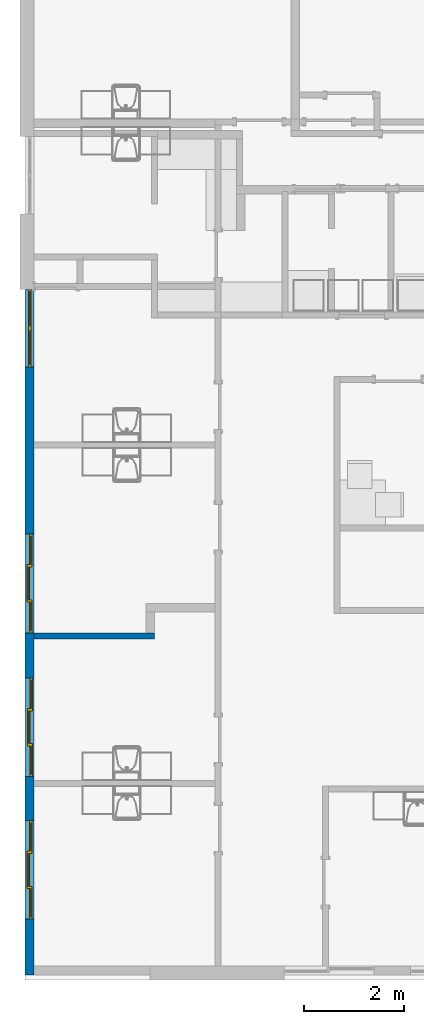
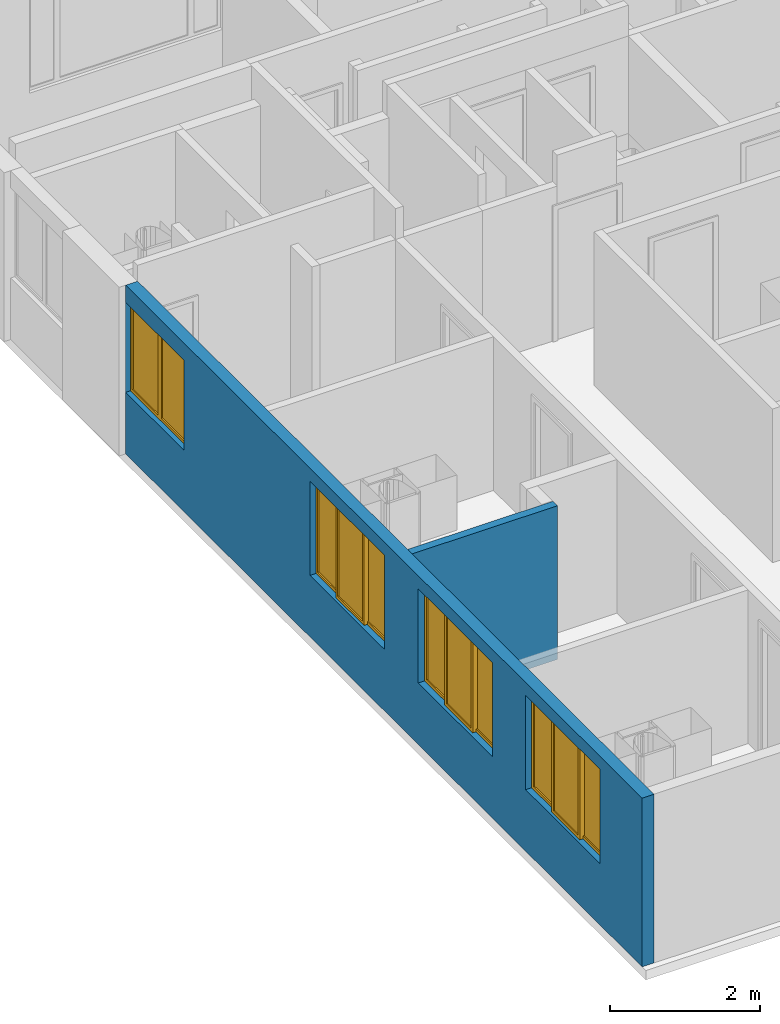
# One storey, part 3 of 64: 4 windows, 2 walls, 4 openings.
"""IFC4 building model written with IfcOpenShell, lengths in feet."""

from ifc_helpers import new_model, entity, si_unit, converted_unit, frame, origin_with_axes, origin_2d_with_axis, place, context, subcontext, project, spatial, line, indexed_curve, outline, extrude, polygons, source, transform, mapped, material, layer, layer_set, layer_usage, type_object, type_shapes, element, fill, save


model = new_model("IFC4")

# Units and contexts
model_context = context("Model", 3, precision=1e-05, world=origin_with_axes())
plan_context = context("Plan", 2, precision=1e-05, world=origin_2d_with_axis())
context_of_model_1 = context(None, 3, precision=1e-05, world=origin_with_axes())
context_of_model_2 = context(None, 3, precision=1e-05, world=origin_with_axes())
body_context = subcontext(model_context, "Body", "Model", "MODEL_VIEW")
ifc_project = project(units=[converted_unit("PLANEANGLEUNIT", "degree", entity("IfcReal", 0.0174532925199433), si_unit("PLANEANGLEUNIT", "RADIAN"), dimensions=[0, 0, 0, 0, 0, 0, 0]), converted_unit("AREAUNIT", "square foot", entity("IfcReal", 0.09290304), si_unit("AREAUNIT", "SQUARE_METRE"), dimensions=[2, 0, 0, 0, 0, 0, 0]), converted_unit("LENGTHUNIT", "foot", entity("IfcReal", 0.3048), si_unit("LENGTHUNIT", "METRE"), dimensions=[1, 0, 0, 0, 0, 0, 0]), converted_unit("VOLUMEUNIT", "cubic foot", entity("IfcReal", 0.0283168467116885), si_unit("VOLUMEUNIT", "CUBIC_METRE"), dimensions=[3, 0, 0, 0, 0, 0, 0])], contexts=[model_context, plan_context, context_of_model_1, context_of_model_2])

# Site, building, storey
site_placement = place(None, origin_with_axes())
site = spatial("IfcSite", under=ifc_project, at=site_placement)
building_placement = place(site_placement, origin_with_axes())
building = spatial("IfcBuilding", under=site, at=building_placement, Name="Building")
storey_placement = place(building_placement, origin_with_axes())
storey = spatial("IfcBuildingStorey", under=building, at=storey_placement, Name="Storey")

# Wall
ifc_material_1 = material()
ifc_layer_1 = layer(ifc_material_1, 0.0520833320915699)
ifc_material_2 = material()
ifc_layer_2 = layer(ifc_material_2, 0.291666656732559)
ifc_layer_3 = layer(ifc_material_1, 0.0520833320915699)
ifc_layer_set_1 = layer_set([ifc_layer_1, ifc_layer_2, ifc_layer_3], Name="poche")
ifc_layer_usage_1 = layer_usage(ifc_layer_set_1, "AXIS2", "POSITIVE", 0.0)
wall_type_1 = type_object("IfcWallType", Name="W4", PredefinedType="STANDARD", material=ifc_layer_set_1)
wall_1_placement = place(storey_placement, frame((-296.996509622088, -10.8710564966277, 0.0), z_axis=(0.0, 0.0, 1.0), x_axis=(1.0, 0.0, 0.0)))
element("IfcWall", 1, at=wall_1_placement, inside=storey, type_object=wall_type_1, material=ifc_layer_usage_1, Name="Wall", context=body_context, shape_type="SweptSolid", body=[
    extrude(outline(indexed_curve([(0.0, 0.0), (0.0, 0.395833320915699), (7.91599748677599, 0.395833320915699), (7.91599748677599, 0.0), (0.0, 0.0)], self_intersect=False)), origin_with_axes(), (0.0, 0.0, 1.0), 8.19791646141393),
])

# Wall, openings, windows
ifc_layer_4 = layer(ifc_material_1, 0.0520833333333333)
ifc_layer_5 = layer(ifc_material_2, 0.458332985639572)
ifc_layer_6 = layer(ifc_material_1, 0.0520833320915699)
ifc_material_3 = material(Name="SPACE")
ifc_layer_7 = layer(ifc_material_3, 0.0416669994592667, Name="Siding")
ifc_layer_set_2 = layer_set([ifc_layer_4, ifc_layer_5, ifc_layer_6, ifc_layer_7], Name="poche")
ifc_layer_usage_2 = layer_usage(ifc_layer_set_2, "AXIS2", "POSITIVE", 0.0)
wall_type_2 = type_object("IfcWallType", PredefinedType="STANDARD", material=ifc_layer_set_2)
wall_2_placement = place(storey_placement, frame((-296.996509622088, -33.0077256430478, 0.0), z_axis=(0.0, 0.0, 1.0), x_axis=(-2.82129974493717e-07, 0.99999999999996, 0.0)))
wall_2 = element("IfcWall", 2, at=wall_2_placement, inside=storey, type_object=wall_type_2, material=ifc_layer_usage_2, Name="Wall", context=body_context, shape_type="SweptSolid", body=[
    extrude(outline(indexed_curve([(0.0, 0.0), (0.0, 0.604166650523742), (45.1347748208851, 0.604166650523742), (45.1347748208851, 0.0), (0.0, 0.0)], self_intersect=False)), origin_with_axes(), (0.0, 0.0, 1.0), 9.00000020900736),
])
shared_shape_1 = source(origin_with_axes(), body_context, "Body", "SweptSolid", [
    extrude(outline(indexed_curve([(0.0, 0.0), (5.10000085830688, 0.0), (5.10000085830688, 4.79999971389771), (0.0, 4.79999971389771)], segments=[line(1, 2, 3, 4, 1)])), frame((0.0, -0.328083992004395, 0.0), z_axis=(0.0, -1.0, 0.0), x_axis=(1.0, 0.0, 0.0)), (0.0, 0.0, -1.0), 1.26033463072902),
])
opening_1_placement = place(wall_2_placement, frame((40.0347722171227, 1.37358128837255e-05, 3.28083989501312), z_axis=(0.0, 0.0, 1.0), x_axis=(1.0, -4.76456032830544e-22, 0.0)))
opening_1 = element("IfcOpeningElement", 3, at=opening_1_placement, cuts=wall_2, Name="Opening", PredefinedType="OPENING", context=body_context, shape_type="MappedRepresentation", body=[
    mapped(shared_shape_1, transform((0.0, 0.0, 0.0), x_axis=(1.0, 0.0, 0.0), y_axis=(0.0, 1.0, 0.0), z_axis=(0.0, 0.0, 1.0), scale=1.0)),
])
shared_shape_2 = source(origin_with_axes(), body_context, "Body", "SweptSolid", [
    extrude(outline(indexed_curve([(0.0, 0.0), (6.50000047683716, 0.0), (6.50000047683716, 5.02568578720093), (0.0, 5.02568578720093)], segments=[line(1, 2, 3, 4, 1)])), frame((0.0, -0.328083992004395, 0.0), z_axis=(0.0, -1.0, 0.0), x_axis=(1.0, 0.0, 0.0)), (0.0, 0.0, -1.0), 1.26033463072902),
])
opening_2_placement = place(wall_2_placement, frame((22.5325003070772, -6.35709353924167e-06, 3.28083989501312), z_axis=(0.0, 0.0, 1.0), x_axis=(1.0, -4.76456032830544e-22, 0.0)))
opening_2 = element("IfcOpeningElement", 4, at=opening_2_placement, cuts=wall_2, Name="Opening", PredefinedType="OPENING", context=body_context, shape_type="MappedRepresentation", body=[
    mapped(shared_shape_2, transform((0.0, 0.0, 0.0), x_axis=(1.0, 0.0, 0.0), y_axis=(0.0, 1.0, 0.0), z_axis=(0.0, 0.0, 1.0), scale=1.0)),
])
opening_3_placement = place(wall_2_placement, frame((13.0646888978207, -3.68594011539075e-06, 3.28083989501312), z_axis=(0.0, 0.0, 1.0), x_axis=(1.0, -4.76456032830544e-22, 0.0)))
opening_3 = element("IfcOpeningElement", 5, at=opening_3_placement, cuts=wall_2, Name="Opening", PredefinedType="OPENING", context=body_context, shape_type="MappedRepresentation", body=[
    mapped(shared_shape_2, transform((0.0, 0.0, 0.0), x_axis=(1.0, 0.0, 0.0), y_axis=(0.0, 1.0, 0.0), z_axis=(0.0, 0.0, 1.0), scale=1.0)),
])
opening_4_placement = place(wall_2_placement, frame((3.68198697648319, -1.03879870001937e-06, 3.28083989501312), z_axis=(0.0, 0.0, 1.0), x_axis=(1.0, -4.76456032830544e-22, 0.0)))
opening_4 = element("IfcOpeningElement", 6, at=opening_4_placement, cuts=wall_2, Name="Opening", PredefinedType="OPENING", context=body_context, shape_type="MappedRepresentation", body=[
    mapped(shared_shape_2, transform((0.0, 0.0, 0.0), x_axis=(1.0, 0.0, 0.0), y_axis=(0.0, 1.0, 0.0), z_axis=(0.0, 0.0, 1.0), scale=1.0)),
])
window_type_1 = type_object("IfcWindowType", PartitioningType="NOTDEFINED", PredefinedType="NOTDEFINED")
shared_shape_3 = source(origin_with_axes(), body_context, "Body", "Tessellation", [
    polygons([(0.15000008046627, 0.164041996002197, 4.87568521499634), (0.15000008046627, 0.164041996002197, 0.149999901652336), (0.0, 0.164041996002197, 0.0), (0.0, 0.164041996002197, 5.02568578720093), (0.0, 0.0, 0.0), (0.0, 0.0, 5.02568578720093), (0.15000008046627, 7.7842932100225e-09, 4.87568521499634), (0.15000008046627, 7.7842932100225e-09, 0.149999901652336), (2.01666736602783, 2.65767141627293e-08, 4.87568521499634), (2.16666746139526, 3.43610153663576e-08, 0.0), (2.16666746139526, 3.43610153663576e-08, 5.02568578720093), (2.01666736602783, 2.65767141627293e-08, 0.149999901652336), (2.16666746139526, 0.164042040705681, 5.02568578720093), (2.16666746139526, 0.164042040705681, 0.0), (2.01666736602783, 0.164042040705681, 0.149999901652336), (2.01666736602783, 0.164042040705681, 4.87568521499634), (2.01666736602783, 0.0656168311834335, 0.149999901652336), (0.15000008046627, 0.0656168088316917, 4.87568521499634), (2.01666736602783, 0.0656168311834335, 4.87568521499634), (0.15000008046627, 0.0656168088316917, 0.149999901652336), (2.01666736602783, 0.0984252244234085, 4.87568521499634), (2.01666736602783, 0.0984252244234085, 0.149999901652336), (0.15000008046627, 0.0984252095222473, 0.149999901652336), (0.15000008046627, 0.0984252095222473, 4.87568521499634), (4.48333263397217, 0.164041802287102, 4.87568521499634), (4.48333263397217, 0.164041802287102, 0.149999901652336), (4.33333253860474, 0.164041802287102, 0.0), (4.33333253860474, 0.164041802287102, 5.02568578720093), (4.33333253860474, -1.89415985119012e-07, 0.0), (4.33333253860474, -1.89415985119012e-07, 5.02568578720093), (4.48333263397217, -1.81631691020812e-07, 4.87568521499634), (4.48333263397217, -1.81631691020812e-07, 0.149999901652336), (6.34999990463257, -1.62839256745428e-07, 4.87568521499634), (6.50000047683716, -1.55054976858082e-07, 0.0), (6.50000047683716, -1.55054976858082e-07, 5.02568578720093), (6.34999990463257, -1.62839256745428e-07, 0.149999901652336), (6.50000047683716, 0.164041846990585, 5.02568578720093), (6.50000047683716, 0.164041846990585, 0.0), (6.34999990463257, 0.164041846990585, 0.149999901652336), (6.34999990463257, 0.164041846990585, 4.87568521499634), (6.34999990463257, 0.065616637468338, 0.149999901652336), (4.48333263397217, 0.0656166225671768, 4.87568521499634), (6.34999990463257, 0.065616637468338, 4.87568521499634), (4.48333263397217, 0.0656166225671768, 0.149999901652336), (6.34999990463257, 0.0984250381588936, 4.87568521499634), (6.34999990463257, 0.0984250381588936, 0.149999901652336), (4.48333263397217, 0.0984250158071518, 0.149999901652336), (4.48333263397217, 0.0984250158071518, 4.87568521499634), (2.16666793823242, 0.328098922967911, 4.87568521499634), (2.16666793823242, 0.328098922967911, 0.149999901652336), (2.01666760444641, 0.328098922967911, 0.0), (2.01666760444641, 0.328098922967911, 5.02568578720093), (2.01666760444641, 0.164056897163391, 0.0), (2.01666760444641, 0.164056897163391, 5.02568578720093), (2.16666793823242, 0.164056897163391, 4.87568521499634), (2.16666793823242, 0.164056897163391, 0.149999901652336), (4.33333349227905, 0.164056867361069, 4.87568521499634), (4.48333406448364, 0.164056867361069, 0.0), (4.48333406448364, 0.164056867361069, 5.02568578720093), (4.33333349227905, 0.164056867361069, 0.149999901652336), (4.48333406448364, 0.328098922967911, 5.02568578720093), (4.48333406448364, 0.328098922967911, 0.0), (4.33333349227905, 0.328098922967911, 0.149999901652336), (4.33333349227905, 0.328098922967911, 4.87568521499634), (4.33333349227905, 0.229673832654953, 0.149999901652336), (2.16666793823242, 0.229673832654953, 4.87568521499634), (4.33333349227905, 0.229673832654953, 4.87568521499634), (2.16666793823242, 0.229673832654953, 0.149999901652336), (4.33333349227905, 0.262482196092606, 4.87568521499634), (4.33333349227905, 0.262482196092606, 0.149999901652336), (2.16666793823242, 0.262482196092606, 0.149999901652336), (2.16666793823242, 0.262482196092606, 4.87568521499634)], [[[2, 3, 1]], [[4, 1, 3]], [[5, 7, 6]], [[5, 8, 7]], [[10, 11, 9]], [[12, 10, 9]], [[7, 11, 6]], [[7, 9, 11]], [[8, 10, 12]], [[5, 10, 8]], [[14, 15, 13]], [[15, 16, 13]], [[16, 1, 13]], [[13, 1, 4]], [[14, 3, 2]], [[14, 2, 15]], [[3, 10, 5]], [[3, 14, 10]], [[11, 10, 14]], [[11, 14, 13]], [[8, 12, 15]], [[15, 2, 8]], [[15, 9, 16]], [[12, 9, 15]], [[4, 6, 11]], [[4, 11, 13]], [[5, 6, 4]], [[5, 4, 3]], [[1, 9, 7]], [[1, 16, 9]], [[7, 8, 2]], [[7, 2, 1]], [[26, 27, 25]], [[28, 25, 27]], [[29, 31, 30]], [[29, 32, 31]], [[34, 35, 33]], [[36, 34, 33]], [[31, 35, 30]], [[31, 33, 35]], [[32, 34, 36]], [[29, 34, 32]], [[38, 39, 37]], [[39, 40, 37]], [[40, 25, 37]], [[37, 25, 28]], [[38, 27, 26]], [[38, 26, 39]], [[27, 34, 29]], [[27, 38, 34]], [[35, 34, 38]], [[35, 38, 37]], [[32, 36, 39]], [[39, 26, 32]], [[39, 33, 40]], [[36, 33, 39]], [[28, 30, 35]], [[28, 35, 37]], [[29, 30, 28]], [[29, 28, 27]], [[25, 33, 31]], [[25, 40, 33]], [[31, 32, 26]], [[31, 26, 25]], [[50, 51, 49]], [[52, 49, 51]], [[53, 55, 54]], [[53, 56, 55]], [[58, 59, 57]], [[60, 58, 57]], [[55, 59, 54]], [[55, 57, 59]], [[56, 58, 60]], [[53, 58, 56]], [[62, 63, 61]], [[63, 64, 61]], [[64, 49, 61]], [[61, 49, 52]], [[62, 51, 50]], [[62, 50, 63]], [[51, 58, 53]], [[51, 62, 58]], [[59, 58, 62]], [[59, 62, 61]], [[56, 60, 63]], [[63, 50, 56]], [[63, 57, 64]], [[60, 57, 63]], [[52, 54, 59]], [[52, 59, 61]], [[53, 54, 52]], [[53, 52, 51]], [[49, 57, 55]], [[49, 64, 57]], [[55, 56, 50]], [[55, 50, 49]]]),
    polygons([(0.15000008046627, 0.164041996002197, 4.87568521499634), (0.15000008046627, 0.164041996002197, 0.149999901652336), (0.0, 0.164041996002197, 0.0), (0.0, 0.164041996002197, 5.02568578720093), (0.0, 0.0, 0.0), (0.0, 0.0, 5.02568578720093), (0.15000008046627, 7.7842932100225e-09, 4.87568521499634), (0.15000008046627, 7.7842932100225e-09, 0.149999901652336), (2.01666736602783, 2.65767141627293e-08, 4.87568521499634), (2.16666746139526, 3.43610153663576e-08, 0.0), (2.16666746139526, 3.43610153663576e-08, 5.02568578720093), (2.01666736602783, 2.65767141627293e-08, 0.149999901652336), (2.16666746139526, 0.164042040705681, 5.02568578720093), (2.16666746139526, 0.164042040705681, 0.0), (2.01666736602783, 0.164042040705681, 0.149999901652336), (2.01666736602783, 0.164042040705681, 4.87568521499634), (2.01666736602783, 0.0656168311834335, 0.149999901652336), (0.15000008046627, 0.0656168088316917, 4.87568521499634), (2.01666736602783, 0.0656168311834335, 4.87568521499634), (0.15000008046627, 0.0656168088316917, 0.149999901652336), (2.01666736602783, 0.0984252244234085, 4.87568521499634), (2.01666736602783, 0.0984252244234085, 0.149999901652336), (0.15000008046627, 0.0984252095222473, 0.149999901652336), (0.15000008046627, 0.0984252095222473, 4.87568521499634), (4.48333263397217, 0.164041802287102, 4.87568521499634), (4.48333263397217, 0.164041802287102, 0.149999901652336), (4.33333253860474, 0.164041802287102, 0.0), (4.33333253860474, 0.164041802287102, 5.02568578720093), (4.33333253860474, -1.89415985119012e-07, 0.0), (4.33333253860474, -1.89415985119012e-07, 5.02568578720093), (4.48333263397217, -1.81631691020812e-07, 4.87568521499634), (4.48333263397217, -1.81631691020812e-07, 0.149999901652336), (6.34999990463257, -1.62839256745428e-07, 4.87568521499634), (6.50000047683716, -1.55054976858082e-07, 0.0), (6.50000047683716, -1.55054976858082e-07, 5.02568578720093), (6.34999990463257, -1.62839256745428e-07, 0.149999901652336), (6.50000047683716, 0.164041846990585, 5.02568578720093), (6.50000047683716, 0.164041846990585, 0.0), (6.34999990463257, 0.164041846990585, 0.149999901652336), (6.34999990463257, 0.164041846990585, 4.87568521499634), (6.34999990463257, 0.065616637468338, 0.149999901652336), (4.48333263397217, 0.0656166225671768, 4.87568521499634), (6.34999990463257, 0.065616637468338, 4.87568521499634), (4.48333263397217, 0.0656166225671768, 0.149999901652336), (6.34999990463257, 0.0984250381588936, 4.87568521499634), (6.34999990463257, 0.0984250381588936, 0.149999901652336), (4.48333263397217, 0.0984250158071518, 0.149999901652336), (4.48333263397217, 0.0984250158071518, 4.87568521499634), (2.16666793823242, 0.328098922967911, 4.87568521499634), (2.16666793823242, 0.328098922967911, 0.149999901652336), (2.01666760444641, 0.328098922967911, 0.0), (2.01666760444641, 0.328098922967911, 5.02568578720093), (2.01666760444641, 0.164056897163391, 0.0), (2.01666760444641, 0.164056897163391, 5.02568578720093), (2.16666793823242, 0.164056897163391, 4.87568521499634), (2.16666793823242, 0.164056897163391, 0.149999901652336), (4.33333349227905, 0.164056867361069, 4.87568521499634), (4.48333406448364, 0.164056867361069, 0.0), (4.48333406448364, 0.164056867361069, 5.02568578720093), (4.33333349227905, 0.164056867361069, 0.149999901652336), (4.48333406448364, 0.328098922967911, 5.02568578720093), (4.48333406448364, 0.328098922967911, 0.0), (4.33333349227905, 0.328098922967911, 0.149999901652336), (4.33333349227905, 0.328098922967911, 4.87568521499634), (4.33333349227905, 0.229673832654953, 0.149999901652336), (2.16666793823242, 0.229673832654953, 4.87568521499634), (4.33333349227905, 0.229673832654953, 4.87568521499634), (2.16666793823242, 0.229673832654953, 0.149999901652336), (4.33333349227905, 0.262482196092606, 4.87568521499634), (4.33333349227905, 0.262482196092606, 0.149999901652336), (2.16666793823242, 0.262482196092606, 0.149999901652336), (2.16666793823242, 0.262482196092606, 4.87568521499634)], [[[17, 19, 18]], [[20, 17, 18]], [[22, 23, 21]], [[23, 24, 21]], [[19, 24, 18]], [[21, 24, 19]], [[18, 24, 20]], [[24, 23, 20]], [[23, 17, 20]], [[23, 22, 17]], [[21, 19, 17]], [[21, 17, 22]], [[41, 43, 42]], [[44, 41, 42]], [[46, 47, 45]], [[47, 48, 45]], [[43, 48, 42]], [[45, 48, 43]], [[42, 48, 44]], [[48, 47, 44]], [[47, 41, 44]], [[47, 46, 41]], [[45, 43, 41]], [[45, 41, 46]], [[65, 67, 66]], [[68, 65, 66]], [[70, 71, 69]], [[71, 72, 69]], [[67, 72, 66]], [[69, 72, 67]], [[66, 72, 68]], [[72, 71, 68]], [[71, 65, 68]], [[71, 70, 65]], [[69, 67, 65]], [[69, 65, 70]]]),
])
type_shapes(window_type_1, [shared_shape_3])
window_1_placement = place(opening_2_placement, frame((3.79720824629107e-08, 0.134590729640851, 2.91397119324188e-15), z_axis=(0.0, 0.0, 1.0), x_axis=(1.0, -9.6530195294842e-24, 0.0)))
window_1 = element("IfcWindow", 7, at=window_1_placement, inside=storey, type_object=window_type_1, Name="Window", context=body_context, shape_type="MappedRepresentation", body=[
    mapped(shared_shape_3, transform((0.0, 0.0, 0.0), x_axis=(1.0, 0.0, 0.0), y_axis=(0.0, 1.0, 0.0), z_axis=(0.0, 0.0, 1.0), scale=1.0)),
])
fill(opening_2, window_1)
window_2_placement = place(opening_3_placement, frame((3.16092471532386e-08, 0.112037959061316, 2.91397119324188e-15), z_axis=(0.0, 0.0, 1.0), x_axis=(1.0, -9.6530195294842e-24, 0.0)))
window_2 = element("IfcWindow", 8, at=window_2_placement, inside=storey, type_object=window_type_1, Name="Window", context=body_context, shape_type="MappedRepresentation", body=[
    mapped(shared_shape_3, transform((0.0, 0.0, 0.0), x_axis=(1.0, 0.0, 0.0), y_axis=(0.0, 1.0, 0.0), z_axis=(0.0, 0.0, 1.0), scale=1.0)),
])
fill(opening_3, window_2)
window_3_placement = place(opening_4_placement, frame((-0.0103376908235855, 0.1369686606431, 2.91397119324188e-15), z_axis=(0.0, 0.0, 1.0), x_axis=(1.0, -9.6530195294842e-24, 0.0)))
window_3 = element("IfcWindow", 9, at=window_3_placement, inside=storey, type_object=window_type_1, Name="Window", context=body_context, shape_type="MappedRepresentation", body=[
    mapped(shared_shape_3, transform((0.0, 0.0, 0.0), x_axis=(1.0, 0.0, 0.0), y_axis=(0.0, 1.0, 0.0), z_axis=(0.0, 0.0, 1.0), scale=1.0)),
])
fill(opening_4, window_3)
window_type_2 = type_object("IfcWindowType", PartitioningType="NOTDEFINED", PredefinedType="NOTDEFINED")
shared_shape_4 = source(origin_with_axes(), body_context, "Body", "Tessellation", [
    polygons([(0.15000008046627, 0.164041996002197, 4.64999914169312), (0.15000008046627, 0.164041996002197, 0.149999901652336), (0.0, 0.164041996002197, 0.0), (0.0, 0.164041996002197, 4.79999971389771), (0.0, 0.0, 0.0), (0.0, 0.0, 4.79999971389771), (0.15000008046627, 7.7842932100225e-09, 4.64999914169312), (0.15000008046627, 7.7842932100225e-09, 0.149999901652336), (2.40000033378601, 9.82069803256991e-09, 4.64999914169312), (2.55000042915344, 1.76049983480198e-08, 0.0), (2.55000042915344, 1.76049983480198e-08, 4.79999971389771), (2.40000033378601, 9.82069803256991e-09, 0.149999901652336), (2.55000042915344, 0.16404202580452, 4.79999971389771), (2.55000042915344, 0.16404202580452, 0.0), (2.40000033378601, 0.16404202580452, 0.149999901652336), (2.40000033378601, 0.16404202580452, 4.64999914169312), (2.40000033378601, 0.0656168088316917, 0.149999901652336), (0.15000008046627, 0.0656168088316917, 4.64999914169312), (2.40000033378601, 0.0656168088316917, 4.64999914169312), (0.15000008046627, 0.0656168088316917, 0.149999901652336), (2.40000033378601, 0.0984252095222473, 4.64999914169312), (2.40000033378601, 0.0984252095222473, 0.149999901652336), (0.15000008046627, 0.0984252095222473, 0.149999901652336), (0.15000008046627, 0.0984252095222473, 4.64999914169312), (2.70000028610229, 0.164041891694069, 4.64999914169312), (2.70000028610229, 0.164041891694069, 0.149999901652336), (2.55000019073486, 0.164041891694069, 0.0), (2.55000019073486, 0.164041891694069, 4.79999971389771), (2.55000019073486, -1.11464046881338e-07, 0.0), (2.55000019073486, -1.11464046881338e-07, 4.79999971389771), (2.70000028610229, -1.03679759888564e-07, 4.64999914169312), (2.70000028610229, -1.03679759888564e-07, 0.149999901652336), (4.95000076293945, -1.01643351513303e-07, 4.64999914169312), (5.10000085830688, -9.38590503096748e-08, 0.0), (5.10000085830688, -9.38590503096748e-08, 4.79999971389771), (4.95000076293945, -1.01643351513303e-07, 0.149999901652336), (5.10000085830688, 0.16404190659523, 4.79999971389771), (5.10000085830688, 0.16404190659523, 0.0), (4.95000076293945, 0.16404190659523, 0.149999901652336), (4.95000076293945, 0.16404190659523, 4.64999914169312), (4.95000076293945, 0.0656166970729828, 0.149999901652336), (2.70000028610229, 0.0656166970729828, 4.64999914169312), (4.95000076293945, 0.0656166970729828, 4.64999914169312), (2.70000028610229, 0.0656166970729828, 0.149999901652336), (4.95000076293945, 0.0984250977635384, 4.64999914169312), (4.95000076293945, 0.0984250977635384, 0.149999901652336), (2.70000028610229, 0.0984250977635384, 0.149999901652336), (2.70000028610229, 0.0984250977635384, 4.64999914169312)], [[[2, 3, 1]], [[4, 1, 3]], [[5, 7, 6]], [[5, 8, 7]], [[10, 11, 9]], [[12, 10, 9]], [[7, 11, 6]], [[7, 9, 11]], [[8, 10, 12]], [[5, 10, 8]], [[14, 15, 13]], [[15, 16, 13]], [[16, 1, 13]], [[13, 1, 4]], [[14, 3, 2]], [[14, 2, 15]], [[3, 10, 5]], [[3, 14, 10]], [[11, 10, 14]], [[11, 14, 13]], [[8, 12, 15]], [[15, 2, 8]], [[15, 9, 16]], [[12, 9, 15]], [[4, 6, 11]], [[4, 11, 13]], [[5, 6, 4]], [[5, 4, 3]], [[1, 9, 7]], [[1, 16, 9]], [[7, 8, 2]], [[7, 2, 1]], [[26, 27, 25]], [[28, 25, 27]], [[29, 31, 30]], [[29, 32, 31]], [[34, 35, 33]], [[36, 34, 33]], [[31, 35, 30]], [[31, 33, 35]], [[32, 34, 36]], [[29, 34, 32]], [[38, 39, 37]], [[39, 40, 37]], [[40, 25, 37]], [[37, 25, 28]], [[38, 27, 26]], [[38, 26, 39]], [[27, 34, 29]], [[27, 38, 34]], [[35, 34, 38]], [[35, 38, 37]], [[32, 36, 39]], [[39, 26, 32]], [[39, 33, 40]], [[36, 33, 39]], [[28, 30, 35]], [[28, 35, 37]], [[29, 30, 28]], [[29, 28, 27]], [[25, 33, 31]], [[25, 40, 33]], [[31, 32, 26]], [[31, 26, 25]]]),
    polygons([(0.15000008046627, 0.164041996002197, 4.64999914169312), (0.15000008046627, 0.164041996002197, 0.149999901652336), (0.0, 0.164041996002197, 0.0), (0.0, 0.164041996002197, 4.79999971389771), (0.0, 0.0, 0.0), (0.0, 0.0, 4.79999971389771), (0.15000008046627, 7.7842932100225e-09, 4.64999914169312), (0.15000008046627, 7.7842932100225e-09, 0.149999901652336), (2.40000033378601, 9.82069803256991e-09, 4.64999914169312), (2.55000042915344, 1.76049983480198e-08, 0.0), (2.55000042915344, 1.76049983480198e-08, 4.79999971389771), (2.40000033378601, 9.82069803256991e-09, 0.149999901652336), (2.55000042915344, 0.16404202580452, 4.79999971389771), (2.55000042915344, 0.16404202580452, 0.0), (2.40000033378601, 0.16404202580452, 0.149999901652336), (2.40000033378601, 0.16404202580452, 4.64999914169312), (2.40000033378601, 0.0656168088316917, 0.149999901652336), (0.15000008046627, 0.0656168088316917, 4.64999914169312), (2.40000033378601, 0.0656168088316917, 4.64999914169312), (0.15000008046627, 0.0656168088316917, 0.149999901652336), (2.40000033378601, 0.0984252095222473, 4.64999914169312), (2.40000033378601, 0.0984252095222473, 0.149999901652336), (0.15000008046627, 0.0984252095222473, 0.149999901652336), (0.15000008046627, 0.0984252095222473, 4.64999914169312), (2.70000028610229, 0.164041891694069, 4.64999914169312), (2.70000028610229, 0.164041891694069, 0.149999901652336), (2.55000019073486, 0.164041891694069, 0.0), (2.55000019073486, 0.164041891694069, 4.79999971389771), (2.55000019073486, -1.11464046881338e-07, 0.0), (2.55000019073486, -1.11464046881338e-07, 4.79999971389771), (2.70000028610229, -1.03679759888564e-07, 4.64999914169312), (2.70000028610229, -1.03679759888564e-07, 0.149999901652336), (4.95000076293945, -1.01643351513303e-07, 4.64999914169312), (5.10000085830688, -9.38590503096748e-08, 0.0), (5.10000085830688, -9.38590503096748e-08, 4.79999971389771), (4.95000076293945, -1.01643351513303e-07, 0.149999901652336), (5.10000085830688, 0.16404190659523, 4.79999971389771), (5.10000085830688, 0.16404190659523, 0.0), (4.95000076293945, 0.16404190659523, 0.149999901652336), (4.95000076293945, 0.16404190659523, 4.64999914169312), (4.95000076293945, 0.0656166970729828, 0.149999901652336), (2.70000028610229, 0.0656166970729828, 4.64999914169312), (4.95000076293945, 0.0656166970729828, 4.64999914169312), (2.70000028610229, 0.0656166970729828, 0.149999901652336), (4.95000076293945, 0.0984250977635384, 4.64999914169312), (4.95000076293945, 0.0984250977635384, 0.149999901652336), (2.70000028610229, 0.0984250977635384, 0.149999901652336), (2.70000028610229, 0.0984250977635384, 4.64999914169312)], [[[17, 19, 18]], [[20, 17, 18]], [[22, 23, 21]], [[23, 24, 21]], [[19, 24, 18]], [[21, 24, 19]], [[18, 24, 20]], [[24, 23, 20]], [[23, 17, 20]], [[23, 22, 17]], [[21, 19, 17]], [[21, 17, 22]], [[41, 43, 42]], [[44, 41, 42]], [[46, 47, 45]], [[47, 48, 45]], [[43, 48, 42]], [[45, 48, 43]], [[42, 48, 44]], [[48, 47, 44]], [[47, 41, 44]], [[47, 46, 41]], [[45, 43, 41]], [[45, 41, 46]]]),
])
type_shapes(window_type_2, [shared_shape_4])
window_4_placement = place(opening_1_placement, frame((0.0104684139187571, 0.194414391155008, 2.91397119324188e-15), z_axis=(0.0, 0.0, 1.0), x_axis=(1.0, -9.6530195294842e-24, 0.0)))
window_4 = element("IfcWindow", 10, at=window_4_placement, inside=storey, type_object=window_type_2, Name="Window", context=body_context, shape_type="MappedRepresentation", body=[
    mapped(shared_shape_4, transform((0.0, 0.0, 0.0), x_axis=(1.0, 0.0, 0.0), y_axis=(0.0, 1.0, 0.0), z_axis=(0.0, 0.0, 1.0), scale=1.0)),
])
fill(opening_1, window_4)

save(model, "model.ifc")
